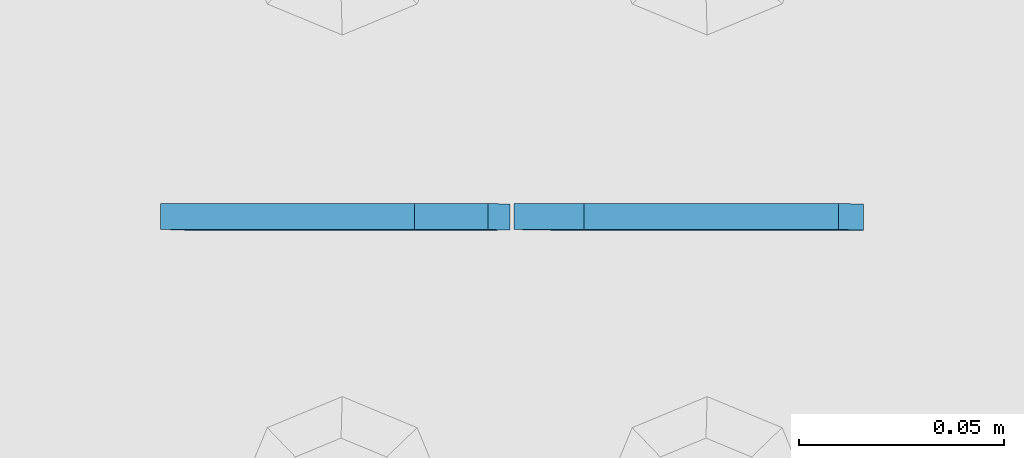
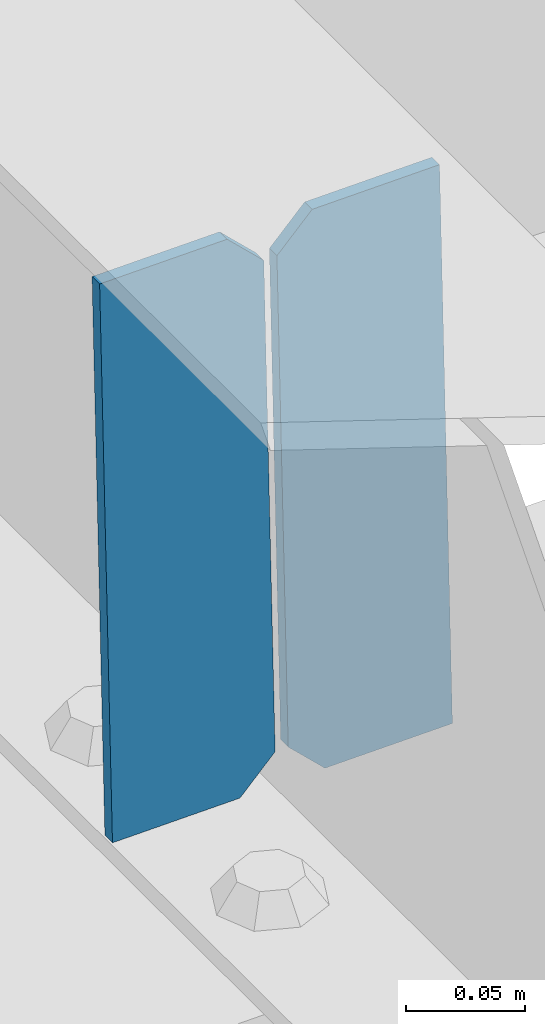
# One storey, part 3466 of 3843: 2 plates, 1 element without a shape of its own.
"""IFC2X3 building model written with IfcOpenShell, lengths in millimetres."""

from ifc_helpers import new_model, si_unit, frame, origin_with_axes, place, context, subcontext, project, spatial, faceted_brep, material, type_object, element, aggregate, save


model = new_model("IFC2X3")

# Units and contexts
model_context = context("Model", 3, precision=1e-05, world=origin_with_axes())
body_context = subcontext(model_context, "Body", "Model", "MODEL_VIEW")
ifc_project = project(units=[si_unit("LENGTHUNIT", "METRE", prefix="MILLI"), si_unit("AREAUNIT", "SQUARE_METRE"), si_unit("VOLUMEUNIT", "CUBIC_METRE"), si_unit("MASSUNIT", "GRAM", prefix="KILO"), si_unit("TIMEUNIT", "SECOND"), si_unit("PLANEANGLEUNIT", "RADIAN"), si_unit("SOLIDANGLEUNIT", "STERADIAN"), si_unit("THERMODYNAMICTEMPERATUREUNIT", "DEGREE_CELSIUS"), si_unit("LUMINOUSINTENSITYUNIT", "LUMEN")], contexts=[model_context])

# Site, building, storey
site_placement = place(None, origin_with_axes())
site = spatial("IfcSite", under=ifc_project, at=site_placement, CompositionType="ELEMENT")
building_placement = place(site_placement, origin_with_axes())
building = spatial("IfcBuilding", under=site, at=building_placement, Name="Undefined", CompositionType="ELEMENT")
storey_placement = place(building_placement, origin_with_axes())
storey = spatial("IfcBuildingStorey", under=building, at=storey_placement, Name="Undefined", CompositionType="ELEMENT", Elevation=0.0)

# Assembly, plates
assembly_placement = place(storey_placement, origin_with_axes())
assembly = element("IfcElementAssembly", 1, at=assembly_placement, inside=storey, Name="BEAM", AssemblyPlace="NOTDEFINED", PredefinedType="RIGID_FRAME")
ifc_material = material(Name="STEEL/A572-50")
plate_type = type_object("IfcPlateType", PredefinedType="NOTDEFINED")
plate_1_placement = place(assembly_placement, frame((50812.4464783761, 92214.3481003043, 45731.159339011), z_axis=(-0.0211520983200607, 0.000772419999964767, 0.999775970957495), x_axis=(-0.999776269340625, -1.63420000828851e-05, -0.0211520920071849)))
plate_1 = element("IfcPlate", 2, at=plate_1_placement, type_object=plate_type, material=ifc_material, Name="STIFFENER", context=body_context, shape_type="Brep", body=[
    faceted_brep([(0.0, -3.17499999999927, 0.0), (6.83940015733242e-10, -3.17499999996653, 288.924999998613), (6.54836185276508e-10, 3.17500000001746, 288.924999998591), (0.0, 3.17499999999927, 0.0), (61.9125003828667, -3.17499999997744, 288.924999998599), (61.9125003828522, 3.17500000002838, 288.924999998584), (79.3750000013097, -3.17499999997744, 271.462500380039), (79.375000001266, 3.17500000002838, 271.462500380017), (79.375000000713, -3.17499999999927, 17.4624996185448), (79.3750000006694, 3.17500000000291, 17.462499618523), (61.9125003821828, -3.17499999999563, -1.45519152283669e-11), (61.9125003821682, 3.17500000000655, -2.91038304567337e-11)], [[[0, 1, 2, 3]], [[1, 4, 5, 2]], [[4, 6, 7, 5]], [[6, 8, 9, 7]], [[8, 10, 11, 9]], [[10, 0, 3, 11]], [[5, 7, 9, 11, 3, 2]], [[10, 8, 6, 4, 1, 0]]]),
])
plate_2_placement = place(assembly_placement, frame((50726.7406576865, 92214.3466993897, 45729.3460759515), z_axis=(-0.0211520983200607, 0.000772419999964767, 0.999775970957495), x_axis=(-0.999776269340625, -1.63420000828851e-05, -0.0211520920071849)))
plate_2 = element("IfcPlate", 3, at=plate_2_placement, type_object=plate_type, material=ifc_material, Name="STIFFENER", context=body_context, shape_type="Brep", body=[
    faceted_brep([(5.82076609134674e-11, -3.17499999999927, 17.4624996185667), (6.25732354819775e-10, -3.17499999997744, 271.462500380054), (5.82076609134674e-10, 3.17500000002474, 271.462500380039), (0.0, 3.17500000000655, 17.4624996185521), (17.462499619156, -3.17499999997744, 288.924999998606), (17.4624996191269, 3.17500000002474, 288.924999998591), (79.3750000013242, -3.17500000025029, 288.924999998591), (79.3750000013097, 3.1749999997337, 288.92499999857), (79.3750000006548, -3.17500000026484, -2.18278728425503e-11), (79.3750000006403, 3.17499999969732, -2.91038304567337e-11), (17.4624996184866, -3.17500000000291, 7.27595761418343e-12), (17.462499618443, 3.17500000000291, -7.27595761418343e-12)], [[[0, 1, 2, 3]], [[1, 4, 5, 2]], [[4, 6, 7, 5]], [[6, 8, 9, 7]], [[8, 10, 11, 9]], [[10, 0, 3, 11]], [[5, 7, 9, 11, 3, 2]], [[10, 8, 6, 4, 1, 0]]]),
])
aggregate(assembly, [plate_1, plate_2])

save(model, "model.ifc")
